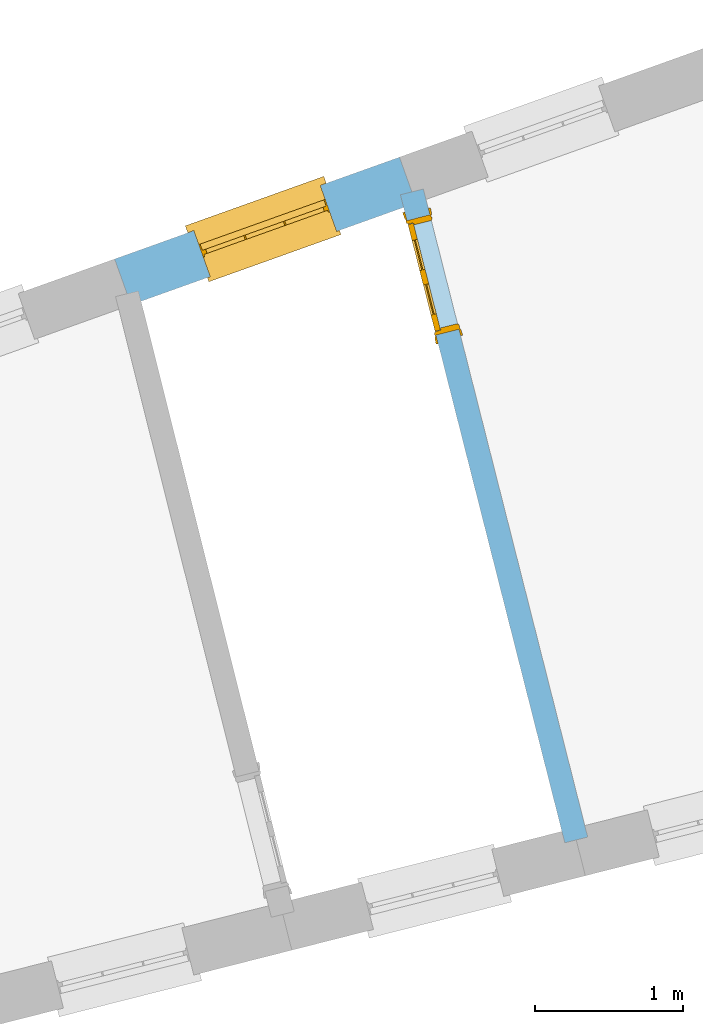
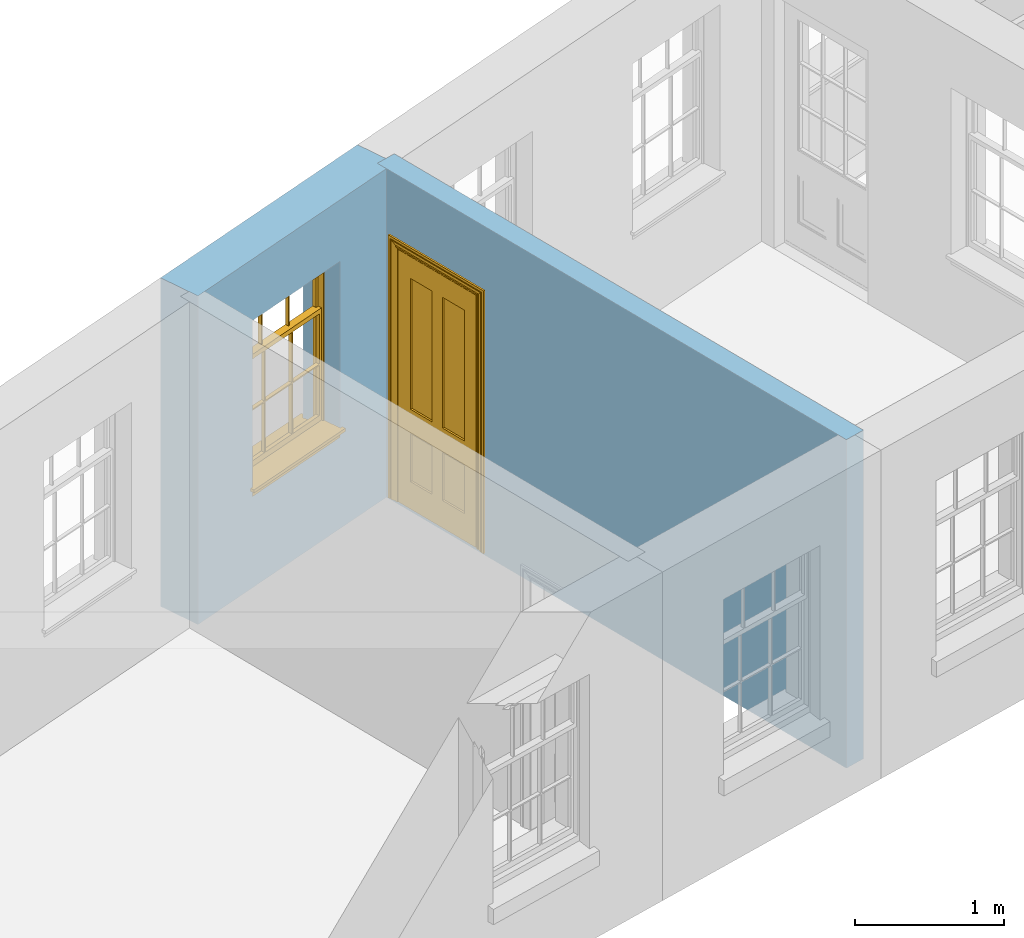
# One storey, part 5 of 10: 1 door, 1 window, 2 openings, plus 2 elements that do not belong to this part.
"""IFC2X3 building model written with IfcOpenShell, lengths in metres."""

from ifc_helpers import new_model, si_unit, frame, origin, place, context, subcontext, project, spatial, polyline, outline, extrude, faceted_brep, material, layer, layer_set, layer_usage, element, fill, save


model = new_model("IFC2X3")

# Units and contexts
model_context = context("Model", 3, world=origin())
body_context = subcontext(model_context, "Body", "Model", "MODEL_VIEW")
ifc_project = project(units=[si_unit("PLANEANGLEUNIT", "RADIAN"), si_unit("MASSUNIT", "GRAM", prefix="KILO"), si_unit("FORCEUNIT", "NEWTON", prefix="KILO"), si_unit("LENGTHUNIT", "METRE")], contexts=[model_context])

# Site, building, storey
site_placement = place(None, origin())
site = spatial("IfcSite", under=ifc_project, at=site_placement, CompositionType="ELEMENT")
building_placement = place(None, origin())
building = spatial("IfcBuilding", under=site, at=building_placement, Name="Building plot-13", CompositionType="ELEMENT")
storey_placement = place(None, frame((0.0, 0.0, 9.55)))
storey = spatial("IfcBuildingStorey", under=building, at=storey_placement, Name="Floor 2", CompositionType="ELEMENT", Elevation=9.55)

# Wall, opening, window
ifc_material_1 = material(Name="Masonry")
ifc_layer_1 = layer(ifc_material_1, 0.33, ventilated=False)
ifc_layer_set_1 = layer_set([ifc_layer_1], Name="My Wall")
ifc_layer_usage_1 = layer_usage(ifc_layer_set_1, "AXIS2", "NEGATIVE", 0.08)
wall_1_placement = place(storey_placement, origin())
wall_1 = element("IfcWallStandardCase", 1, at=wall_1_placement, inside=storey, material=ifc_layer_usage_1, Name="exterior", context=body_context, shape_type="SweptSolid", body=[
    extrude(outline(polyline([(72.090338058868, 49.7513205451126), (71.9792289491637, 50.0620531725284), (70.0510857180657, 49.3726042415572), (70.16219482777, 49.0618716141414), (72.090338058868, 49.7513205451126)])), origin(), (0.0, 0.0, 1.0), 2.7),
])
opening_1_placement = place(storey_placement, frame((0.0, 0.0, 0.75)))
opening_1 = element("IfcOpeningElement", 2, at=opening_1_placement, cuts=wall_1, Name="Opening", ObjectType="Opening", context=body_context, shape_type="SweptSolid", body=[
    extrude(outline(polyline([(71.4435917138395, 49.870524600726), (70.5867229533899, 49.5641328133596), (70.6978320630942, 49.2534001859438), (71.5547008235438, 49.5597919733102), (71.4435917138395, 49.870524600726)])), origin(), (0.0, 0.0, 1.0), 1.445),
])
window_placement = place(storey_placement, frame((71.5277652817973, 49.635121095108, 0.75), z_axis=(0.0, 0.0, 1.0), x_axis=(-0.856868760449586, -0.306391787366422, 0.0)))
window = element("IfcWindow", 3, at=window_placement, inside=storey, Name="circulation outside window", OverallHeight=1.445, OverallWidth=0.91, context=body_context, shape_type="Brep", held_by="IfcProductRepresentation", body=[
    faceted_brep([(0.876875, -0.105, 0.999097), (0.876875, -0.105, 1.411875), (0.9, -0.105, 1.435), (0.033125, -0.105, 1.411875), (0.033125, -0.105, 0.999097), (0.01, -0.105, 1.435), (0.033125, -0.135, 1.411875), (0.01, -0.135, 1.435), (0.033125, -0.135, 0.999097), (0.876875, -0.135, 1.411875), (0.876875, -0.135, 0.999097), (0.9, -0.135, 1.435), (0.033125, -0.105, 0.960972), (0.01, -0.105, 0.960972), (0.033125, -0.105, 0.548195), (0.876875, -0.105, 0.960972), (0.876875, -0.105, 0.548195), (0.9, -0.105, 0.960972), (0.876875, -0.105, 0.538195), (0.876875, -0.105, 0.125417), (0.9, -0.105, 0.077167), (0.033125, -0.105, 0.125417), (0.033125, -0.105, 0.538195), (0.01, -0.105, 0.077167), (0.9, -0.135, 0.960972), (0.01, -0.135, 0.960972), (-0.0425, -0.25, 0.01), (-0.0425, -0.3, 0.001667), (0.0, -0.25, 0.01), (0.9525, -0.25, 0.01), (0.91, -0.25, 0.01), (0.9525, -0.3, 0.001667), (-0.02, 0.08, 0.077167), (0.0, 0.08, 0.077167), (-0.02, 0.11, 0.077167), (0.0, -0.06, 0.077167), (0.01, -0.06, 0.077167), (0.91, -0.06, 0.077167), (0.91, 0.08, 0.077167), (0.9, -0.06, 0.077167), (0.93, 0.08, 0.077167), (0.93, 0.11, 0.077167), (0.01, -0.105, 0.999097), (0.01, -0.075, 0.999097), (0.9, -0.105, 0.999097), (0.9, -0.075, 0.999097), (0.876875, -0.075, 0.125417), (0.876875, -0.075, 0.538195), (0.9, -0.075, 0.077167), (0.876875, -0.075, 0.548195), (0.876875, -0.075, 0.960972), (0.033125, -0.075, 0.125417), (0.01, -0.075, 0.077167), (0.033125, -0.075, 0.538195), (0.033125, -0.075, 0.960972), (0.033125, -0.075, 0.548195), (-0.02, 0.08, 0.052167), (-0.02, 0.11, 0.052167), (0.93, 0.11, 0.052167), (0.93, 0.08, 0.052167), (0.91, 0.08, 0.052167), (0.0, 0.08, 0.052167), (0.91, -0.15, 0.026667), (0.0, -0.15, 0.026667), (-0.0425, -0.3, -0.123333), (0.9525, -0.3, -0.123333), (-0.0425, -0.25, -0.123333), (0.9525, -0.25, -0.123333), (0.01, -0.06, 1.435), (0.9, -0.06, 1.435), (0.0, -0.06, 1.445), (0.91, -0.06, 1.445), (0.01, -0.15, 0.077167), (0.9, -0.15, 0.077167), (0.592292, -0.105, 0.125417), (0.592292, -0.075, 0.125417), (0.317708, -0.075, 0.125417), (0.317708, -0.105, 0.125417), (0.592292, -0.105, 0.548195), (0.317708, -0.105, 0.548195), (0.317708, -0.105, 0.538195), (0.592292, -0.105, 0.538195), (0.592292, -0.075, 0.548195), (0.317708, -0.075, 0.548195), (0.602292, -0.075, 0.548195), (0.602292, -0.105, 0.548195), (0.317708, -0.075, 0.538195), (0.307708, -0.075, 0.125417), (0.307708, -0.075, 0.538195), (0.602292, -0.075, 0.538195), (0.602292, -0.075, 0.125417), (0.592292, -0.075, 0.538195), (0.307708, -0.075, 0.548195), (0.317708, -0.075, 0.960972), (0.307708, -0.075, 0.960972), (0.602292, -0.075, 0.960972), (0.592292, -0.075, 0.960972), (0.307708, -0.105, 0.538195), (0.307708, -0.105, 0.125417), (0.307708, -0.105, 0.548195), (0.307708, -0.105, 0.960972), (0.592292, -0.105, 0.960972), (0.317708, -0.105, 0.960972), (0.602292, -0.105, 0.960972), (0.602292, -0.105, 0.538195), (0.602292, -0.105, 0.125417), (0.317708, -0.135, 1.411875), (0.307708, -0.135, 1.411875), (0.307708, -0.135, 0.999097), (0.317708, -0.135, 0.999097), (0.602292, -0.135, 1.411875), (0.592292, -0.135, 1.411875), (0.592292, -0.135, 0.999097), (0.602292, -0.135, 0.999097), (0.317708, -0.105, 0.999097), (0.307708, -0.105, 0.999097), (0.307708, -0.105, 1.411875), (0.317708, -0.105, 1.411875), (0.602292, -0.105, 0.999097), (0.592292, -0.105, 0.999097), (0.592292, -0.105, 1.411875), (0.602292, -0.105, 1.411875), (0.91, -0.15, 1.445), (0.9, -0.15, 1.435), (0.01, -0.15, 1.435), (0.0, -0.15, 1.445), (0.91, -0.25, 0.0), (0.0, -0.25, 0.0), (0.91, 0.08, 0.0), (0.0, 0.08, 0.0)], [[[0, 1, 2]], [[3, 4, 5]], [[6, 7, 8]], [[9, 10, 11]], [[12, 13, 14]], [[15, 16, 17]], [[18, 19, 20]], [[21, 22, 23]], [[24, 15, 17]], [[13, 12, 25]], [[26, 27, 28]], [[29, 30, 31]], [[32, 33, 34]], [[35, 36, 33]], [[37, 38, 39]], [[40, 41, 38]], [[42, 4, 43]], [[44, 45, 0]], [[46, 47, 48]], [[49, 50, 45]], [[51, 52, 53]], [[54, 55, 43]], [[38, 33, 36, 39]], [[41, 34, 33, 38]], [[56, 32, 34, 57]], [[57, 34, 41, 58]], [[58, 41, 40, 59]], [[57, 58, 60, 61]], [[52, 48, 39, 36]], [[62, 63, 28, 30]], [[27, 31, 30, 28]], [[27, 64, 65, 31]], [[66, 67, 65, 64]], [[2, 5, 68, 69]], [[68, 70, 71, 69]], [[20, 23, 72, 73]], [[73, 72, 63, 62]], [[74, 75, 76, 77]], [[78, 79, 80, 81]], [[78, 82, 83, 79]], [[16, 49, 84, 85]], [[86, 76, 87, 88]], [[89, 90, 75, 91]], [[92, 88, 53, 55]], [[82, 91, 86, 83]], [[93, 83, 92, 94]], [[95, 84, 82, 96]], [[89, 84, 49, 47]], [[97, 88, 87, 98]], [[22, 53, 88, 97]], [[81, 91, 75, 74]], [[80, 86, 91, 81]], [[77, 76, 86, 80]], [[99, 92, 55, 14]], [[100, 94, 92, 99]], [[101, 96, 82, 78]], [[79, 83, 93, 102]], [[85, 84, 95, 103]], [[104, 89, 47, 18]], [[105, 90, 89, 104]], [[104, 18, 16, 85]], [[80, 97, 98, 77]], [[104, 81, 74, 105]], [[103, 101, 78, 85]], [[99, 14, 22, 97]], [[102, 100, 99, 79]], [[106, 107, 108, 109]], [[110, 111, 112, 113]], [[114, 115, 116, 117]], [[118, 119, 120, 121]], [[107, 116, 115, 108]], [[111, 120, 119, 112]], [[109, 114, 117, 106]], [[113, 118, 121, 110]], [[85, 78, 81, 104]], [[84, 89, 91, 82]], [[83, 86, 88, 92]], [[79, 99, 97, 80]], [[109, 112, 119, 114]], [[102, 93, 96, 101]], [[106, 117, 120, 111]], [[98, 87, 51, 21]], [[6, 3, 116, 107]], [[110, 121, 1, 9]], [[19, 46, 90, 105]], [[26, 66, 64, 27]], [[29, 31, 65, 67]], [[25, 24, 112, 109]], [[11, 7, 106, 111]], [[75, 48, 52, 76]], [[43, 45, 96, 93]], [[45, 43, 114, 119]], [[5, 2, 120, 117]], [[24, 25, 102, 101]], [[42, 5, 4]], [[2, 44, 0]], [[49, 45, 48, 47]], [[52, 43, 55, 53]], [[14, 13, 23, 22]], [[20, 17, 16, 18]], [[24, 11, 10]], [[25, 8, 7]], [[8, 4, 3, 6]], [[9, 1, 0, 10]], [[15, 50, 49, 16]], [[18, 47, 46, 19]], [[21, 51, 53, 22]], [[14, 55, 54, 12]], [[44, 2, 69, 45]], [[68, 5, 42, 43]], [[36, 35, 70, 68]], [[39, 69, 71, 37]], [[62, 122, 123, 73]], [[63, 72, 124, 125]], [[8, 108, 115, 4]], [[113, 10, 0, 118]], [[94, 100, 12, 54]], [[17, 20, 73, 24]], [[72, 23, 13, 25]], [[52, 36, 68, 43]], [[69, 39, 48, 45]], [[11, 24, 73, 123]], [[7, 124, 72, 25]], [[23, 77, 98]], [[98, 21, 23]], [[105, 74, 20]], [[20, 19, 105]], [[20, 74, 77, 23]], [[113, 112, 24]], [[24, 10, 113]], [[25, 109, 108]], [[108, 8, 25]], [[110, 9, 11]], [[11, 111, 110]], [[7, 6, 107]], [[107, 106, 7]], [[5, 117, 116]], [[116, 3, 5]], [[121, 120, 2]], [[2, 1, 121]], [[11, 123, 124, 7]], [[122, 125, 124, 123]], [[43, 93, 94]], [[94, 54, 43]], [[96, 45, 95]], [[50, 95, 45]], [[15, 103, 95, 50]], [[48, 75, 90]], [[90, 46, 48]], [[87, 76, 52]], [[52, 51, 87]], [[103, 15, 24]], [[24, 101, 103]], [[100, 102, 25]], [[25, 12, 100]], [[115, 114, 43]], [[43, 4, 115]], [[118, 0, 45]], [[45, 119, 118]], [[71, 70, 125, 122]], [[70, 35, 63, 125]], [[122, 62, 37, 71]], [[126, 67, 66, 127]], [[60, 58, 59]], [[38, 60, 59, 40]], [[61, 56, 57]], [[32, 56, 61, 33]], [[61, 60, 128, 129]], [[62, 60, 38, 37]], [[126, 128, 60, 62]], [[33, 61, 63, 35]], [[61, 129, 127, 63]], [[128, 126, 127, 129]], [[28, 127, 66, 26]], [[63, 127, 28]], [[29, 67, 126, 30]], [[30, 126, 62]]]),
])
fill(opening_1, window)

# Wall, opening, door
ifc_material_2 = material(Name="Masonry")
ifc_layer_2 = layer(ifc_material_2, 0.16, ventilated=False)
ifc_layer_set_2 = layer_set([ifc_layer_2], Name="My Wall")
ifc_layer_usage_2 = layer_usage(ifc_layer_set_2, "AXIS2", "NEGATIVE", 0.08)
wall_2_placement = place(storey_placement, origin())
wall_2 = element("IfcWallStandardCase", 4, at=wall_2_placement, inside=storey, material=ifc_layer_usage_2, Name="interior", context=body_context, shape_type="SweptSolid", body=[
    extrude(outline(polyline([(73.0984173418015, 45.4203864890174), (73.2535068796829, 45.459721400225), (72.1409472860622, 49.8463171225142), (71.9858577481808, 49.8069822113066), (73.0984173418015, 45.4203864890174)])), origin(), (0.0, 0.0, 1.0), 2.7),
])
opening_2_placement = place(storey_placement, frame((0.0, 0.0, 0.0199999999999996)))
opening_2 = element("IfcOpeningElement", 5, at=opening_2_placement, cuts=wall_2, Name="Opening", ObjectType="Opening", context=body_context, shape_type="SweptSolid", body=[
    extrude(outline(polyline([(72.3818736172093, 48.8963937029903), (72.1851990611709, 49.6718413923976), (72.0301095232894, 49.6325064811899), (72.2267840793278, 48.8570587917826), (72.3818736172093, 48.8963937029903)])), origin(), (0.0, 0.0, 1.0), 2.1),
])
door_placement = place(storey_placement, frame((72.3043288482685, 48.8767262473865, 0.0199999999999996), z_axis=(0.0, 0.0, 1.0), x_axis=(-0.196674556038388, 0.775447689407294, 0.0)))
door = element("IfcDoor", 6, at=door_placement, inside=storey, Name="bedroom inside door", OverallHeight=2.1, OverallWidth=0.8, context=body_context, shape_type="Brep", held_by="IfcProductRepresentation", body=[
    faceted_brep([(0.773, 0.08, 1.895), (0.66, 0.08, 1.895), (0.66, 0.08, 2.073), (0.773, 0.08, 2.073), (0.773, 0.08, 0.82), (0.66, 0.08, 0.82), (0.45, 0.08, 1.895), (0.45, 0.08, 2.073), (0.773, 0.08, 0.62), (0.66, 0.08, 0.62), (0.66, 0.065, 0.82), (0.66, 0.065, 1.895), (0.45, 0.065, 1.895), (0.35, 0.08, 1.895), (0.35, 0.08, 2.073), (0.773, 0.08, 0.225), (0.66, 0.08, 0.225), (0.45, 0.08, 0.62), (0.45, 0.08, 0.82), (0.45, 0.065, 0.82), (0.35, 0.08, 0.82), (0.14, 0.08, 2.073), (0.14, 0.08, 1.895), (0.773, 0.08, 0.0), (0.66, 0.08, 0.0), (0.66, 0.065, 0.225), (0.66, 0.065, 0.62), (0.45, 0.065, 0.62), (0.35, 0.08, 0.62), (0.35, 0.065, 0.82), (0.35, 0.065, 1.895), (0.14, 0.065, 1.895), (0.027, 0.08, 2.073), (0.027, 0.08, 1.895), (0.773, 0.042, 0.0), (0.66, 0.042, 0.0), (0.45, 0.08, 0.0), (0.45, 0.08, 0.225), (0.45, 0.065, 0.225), (0.35, 0.08, 0.225), (0.14, 0.08, 0.82), (0.14, 0.08, 0.62), (0.14, 0.065, 0.82), (0.027, 0.08, 0.82), (0.773, 0.042, 0.225), (0.66, 0.042, 0.225), (0.45, 0.042, 0.0), (0.35, 0.08, 0.0), (0.35, 0.065, 0.225), (0.35, 0.065, 0.62), (0.14, 0.065, 0.62), (0.027, 0.08, 0.62), (0.773, 0.042, 0.62), (0.66, 0.042, 0.62), (0.45, 0.042, 0.225), (0.35, 0.042, 0.0), (0.14, 0.08, 0.225), (0.14, 0.08, 0.0), (0.14, 0.065, 0.225), (0.027, 0.08, 0.225), (0.773, 0.042, 0.82), (0.66, 0.042, 0.82), (0.66, 0.057, 0.62), (0.66, 0.057, 0.225), (0.45, 0.057, 0.225), (0.35, 0.042, 0.225), (0.14, 0.042, 0.0), (0.027, 0.08, 0.0), (0.773, 0.042, 1.895), (0.66, 0.042, 1.895), (0.45, 0.042, 0.62), (0.45, 0.042, 0.82), (0.45, 0.057, 0.62), (0.35, 0.042, 0.62), (0.14, 0.042, 0.225), (0.027, 0.042, 0.0), (0.773, 0.042, 2.073), (0.66, 0.042, 2.073), (0.66, 0.057, 1.895), (0.66, 0.057, 0.82), (0.45, 0.057, 0.82), (0.35, 0.042, 0.82), (0.35, 0.057, 0.62), (0.35, 0.057, 0.225), (0.14, 0.057, 0.225), (0.027, 0.042, 0.225), (0.45, 0.042, 1.895), (0.45, 0.042, 2.073), (0.45, 0.057, 1.895), (0.35, 0.042, 1.895), (0.14, 0.042, 0.82), (0.14, 0.042, 0.62), (0.14, 0.057, 0.62), (0.027, 0.042, 0.62), (0.35, 0.042, 2.073), (0.35, 0.057, 1.895), (0.35, 0.057, 0.82), (0.14, 0.057, 0.82), (0.027, 0.042, 0.82), (0.14, 0.042, 2.073), (0.14, 0.042, 1.895), (0.14, 0.057, 1.895), (0.027, 0.042, 1.895), (0.027, 0.042, 2.073), (0.02, 0.085, 0.0), (0.005, 0.09, 0.0), (0.005, 0.09, 2.095), (0.02, 0.085, 2.08), (0.02, 0.08, 0.0), (0.0, 0.085, 0.0), (0.0, 0.085, 2.1), (0.795, 0.09, 2.095), (0.78, 0.085, 2.08), (0.02, 0.08, 2.08), (0.0, 0.08, 0.0), (-0.032, 0.095, 0.0), (-0.032, 0.095, 2.132), (0.8, 0.085, 2.1), (0.795, 0.09, 0.0), (0.78, 0.085, 0.0), (0.78, 0.08, 2.08), (0.04, 0.04, 0.0), (0.025, 0.04, 0.0), (0.025, 0.04, 2.075), (0.04, 0.04, 2.06), (-0.04, 0.09, 0.0), (-0.04, 0.09, 2.14), (0.832, 0.095, 2.132), (0.8, 0.085, 0.0), (0.78, 0.08, 0.0), (0.8, 0.08, 0.0), (0.86, 0.08, 0.0), (0.86, 0.08, 2.16), (0.8, 0.08, 2.1), (-0.06, 0.08, 2.16), (0.0, 0.08, 2.1), (-0.06, 0.08, 0.0), (-0.04, 0.095, 0.0), (-0.04, 0.095, 2.14), (0.84, 0.09, 2.14), (0.832, 0.095, 0.0), (0.84, 0.09, 0.0), (0.86, 0.095, 0.0), (0.86, 0.095, 2.16), (-0.06, 0.095, 2.16), (-0.06, 0.095, 0.0), (0.84, 0.095, 0.0), (0.84, 0.095, 2.14), (-0.025, -0.095, 0.0), (-0.025, -0.09, 0.0), (-0.025, -0.09, 2.125), (-0.025, -0.095, 2.125), (-0.017, -0.095, 0.0), (-0.017, -0.095, 2.117), (0.825, -0.09, 2.125), (0.825, -0.095, 2.125), (0.825, -0.095, 0.0), (0.845, -0.095, 0.0), (-0.045, -0.095, 2.145), (-0.045, -0.095, 0.0), (0.845, -0.095, 2.145), (0.015, -0.085, 0.0), (0.015, -0.085, 2.085), (0.817, -0.095, 2.117), (0.825, -0.09, 0.0), (0.845, -0.08, 0.0), (0.845, -0.08, 2.145), (-0.045, -0.08, 2.145), (-0.045, -0.08, 0.0), (0.02, -0.09, 0.0), (0.02, -0.09, 2.08), (0.785, -0.085, 2.085), (0.817, -0.095, 0.0), (0.8, -0.08, 0.0), (0.8, -0.08, 2.1), (0.0, -0.08, 2.1), (0.0, -0.08, 0.0), (0.035, -0.085, 0.0), (0.035, -0.085, 2.065), (0.78, -0.09, 2.08), (0.785, -0.085, 0.0), (0.775, 0.04, 2.075), (0.76, 0.04, 2.06), (0.035, -0.08, 2.065), (0.035, -0.08, 0.0), (0.765, -0.085, 2.065), (0.78, -0.09, 0.0), (0.765, -0.08, 0.0), (0.765, -0.08, 2.065), (0.765, -0.085, 0.0), (0.04, -0.08, 2.06), (0.04, -0.08, 0.0), (0.76, -0.08, 2.06), (0.76, -0.08, 0.0), (0.76, 0.04, 0.0), (0.775, 0.04, 0.0), (0.025, 0.08, 0.0), (0.025, 0.08, 2.075), (0.775, 0.08, 0.0), (0.775, 0.08, 2.075)], [[[0, 1, 2, 3]], [[1, 0, 4, 5]], [[1, 6, 7, 2]], [[8, 9, 5, 4]], [[1, 5, 10, 11]], [[6, 1, 11, 12]], [[6, 13, 14, 7]], [[15, 16, 9, 8]], [[9, 17, 18, 5]], [[5, 18, 19, 10]], [[10, 19, 12, 11]], [[18, 6, 12, 19]], [[18, 20, 13, 6]], [[21, 14, 13, 22]], [[23, 24, 16, 15]], [[9, 16, 25, 26]], [[17, 9, 26, 27]], [[17, 28, 20, 18]], [[13, 20, 29, 30]], [[22, 13, 30, 31]], [[32, 21, 22, 33]], [[34, 35, 24, 23]], [[24, 36, 37, 16]], [[16, 37, 38, 25]], [[25, 38, 27, 26]], [[37, 17, 27, 38]], [[37, 39, 28, 17]], [[40, 20, 28, 41]], [[20, 40, 42, 29]], [[31, 30, 29, 42]], [[40, 22, 31, 42]], [[33, 22, 40, 43]], [[35, 34, 44, 45]], [[35, 46, 36, 24]], [[36, 47, 39, 37]], [[28, 39, 48, 49]], [[41, 28, 49, 50]], [[43, 40, 41, 51]], [[45, 44, 52, 53]], [[46, 35, 45, 54]], [[46, 55, 47, 36]], [[56, 39, 47, 57]], [[39, 56, 58, 48]], [[50, 49, 48, 58]], [[56, 41, 50, 58]], [[51, 41, 56, 59]], [[53, 52, 60, 61]], [[45, 53, 62, 63]], [[54, 45, 63, 64]], [[55, 46, 54, 65]], [[55, 66, 57, 47]], [[59, 56, 57, 67]], [[61, 60, 68, 69]], [[70, 53, 61, 71]], [[53, 70, 72, 62]], [[72, 64, 63, 62]], [[70, 54, 64, 72]], [[65, 54, 70, 73]], [[65, 74, 66, 55]], [[67, 57, 66, 75]], [[69, 68, 76, 77]], [[61, 69, 78, 79]], [[71, 61, 79, 80]], [[73, 70, 71, 81]], [[65, 73, 82, 83]], [[74, 65, 83, 84]], [[74, 85, 75, 66]], [[86, 69, 77, 87]], [[69, 86, 88, 78]], [[88, 80, 79, 78]], [[86, 71, 80, 88]], [[81, 71, 86, 89]], [[73, 81, 90, 91]], [[73, 91, 92, 82]], [[83, 82, 92, 84]], [[91, 74, 84, 92]], [[91, 93, 85, 74]], [[89, 86, 87, 94]], [[81, 89, 95, 96]], [[90, 81, 96, 97]], [[90, 98, 93, 91]], [[94, 99, 100, 89]], [[89, 100, 101, 95]], [[101, 97, 96, 95]], [[100, 90, 97, 101]], [[100, 102, 98, 90]], [[99, 103, 102, 100]], [[32, 103, 99, 21]], [[102, 103, 32, 33]], [[98, 102, 33, 43]], [[21, 99, 94, 14]], [[94, 87, 7, 14]], [[7, 87, 77, 2]], [[76, 3, 2, 77]], [[43, 51, 93, 98]], [[51, 59, 85, 93]], [[67, 75, 85, 59]], [[34, 23, 15, 44]], [[44, 15, 8, 52]], [[52, 8, 4, 60]], [[0, 68, 60, 4]], [[0, 3, 76, 68]], [[104, 105, 106, 107]], [[104, 108, 109, 105]], [[105, 109, 110, 106]], [[107, 106, 111, 112]], [[107, 113, 108, 104]], [[114, 109, 108]], [[109, 115, 116, 110]], [[106, 110, 117, 111]], [[112, 111, 118, 119]], [[113, 107, 112, 120]], [[121, 122, 123, 124]], [[115, 109, 114, 125]], [[115, 125, 126, 116]], [[110, 116, 127, 117]], [[111, 117, 128, 118]], [[118, 128, 129, 119]], [[120, 112, 119, 129]], [[130, 129, 128]], [[130, 131, 132, 133]], [[133, 132, 134, 135]], [[135, 134, 136, 114]], [[136, 125, 114]], [[125, 137, 138, 126]], [[116, 126, 139, 127]], [[117, 127, 140, 128]], [[141, 130, 128, 140]], [[131, 130, 141]], [[131, 142, 143, 132]], [[132, 143, 144, 134]], [[134, 144, 145, 136]], [[137, 125, 136, 145]], [[143, 142, 146]], [[143, 146, 147]], [[137, 145, 144]], [[143, 147, 138]], [[138, 137, 144]], [[143, 138, 144]], [[126, 138, 147, 139]], [[127, 139, 141, 140]], [[142, 131, 141, 146]], [[139, 147, 146, 141]], [[148, 149, 150, 151]], [[149, 152, 153, 150]], [[151, 150, 154, 155]], [[155, 156, 157]], [[158, 159, 148]], [[158, 148, 151]], [[155, 157, 160]], [[158, 151, 155]], [[155, 160, 158]], [[152, 161, 162, 153]], [[150, 153, 163, 154]], [[155, 154, 164, 156]], [[156, 164, 165, 157]], [[157, 165, 166, 160]], [[160, 166, 167, 158]], [[158, 167, 168, 159]], [[161, 169, 170, 162]], [[153, 162, 171, 163]], [[154, 163, 172, 164]], [[165, 164, 173]], [[165, 173, 174, 166]], [[166, 174, 175, 167]], [[167, 175, 176, 168]], [[169, 177, 178, 170]], [[162, 170, 179, 171]], [[163, 171, 180, 172]], [[172, 180, 173, 164]], [[124, 123, 181, 182]], [[183, 178, 177, 184]], [[170, 178, 185, 179]], [[171, 179, 186, 180]], [[187, 173, 180]], [[185, 188, 187, 189]], [[188, 185, 178, 183]], [[179, 185, 189, 186]], [[189, 187, 180, 186]], [[190, 183, 184, 191]], [[192, 188, 183, 190]], [[191, 184, 122, 121]], [[124, 190, 191, 121]], [[193, 187, 188, 192]], [[182, 192, 190, 124]], [[184, 176, 122]], [[194, 195, 187, 193]], [[192, 182, 194, 193]], [[161, 176, 184]], [[114, 108, 122, 176]], [[173, 187, 195]], [[152, 149, 176, 161]], [[169, 161, 184, 177]], [[196, 122, 108]], [[176, 175, 135, 114]], [[173, 195, 129, 130]], [[176, 149, 168]], [[123, 122, 196, 197]], [[196, 108, 113, 197]], [[175, 174, 133, 135]], [[198, 129, 195]], [[133, 174, 173, 130]], [[159, 168, 149, 148]], [[181, 123, 197, 199]], [[197, 113, 120, 199]], [[199, 120, 129, 198]], [[195, 181, 199, 198]], [[195, 194, 182, 181]]]),
])
fill(opening_2, door)

save(model, "model.ifc")
